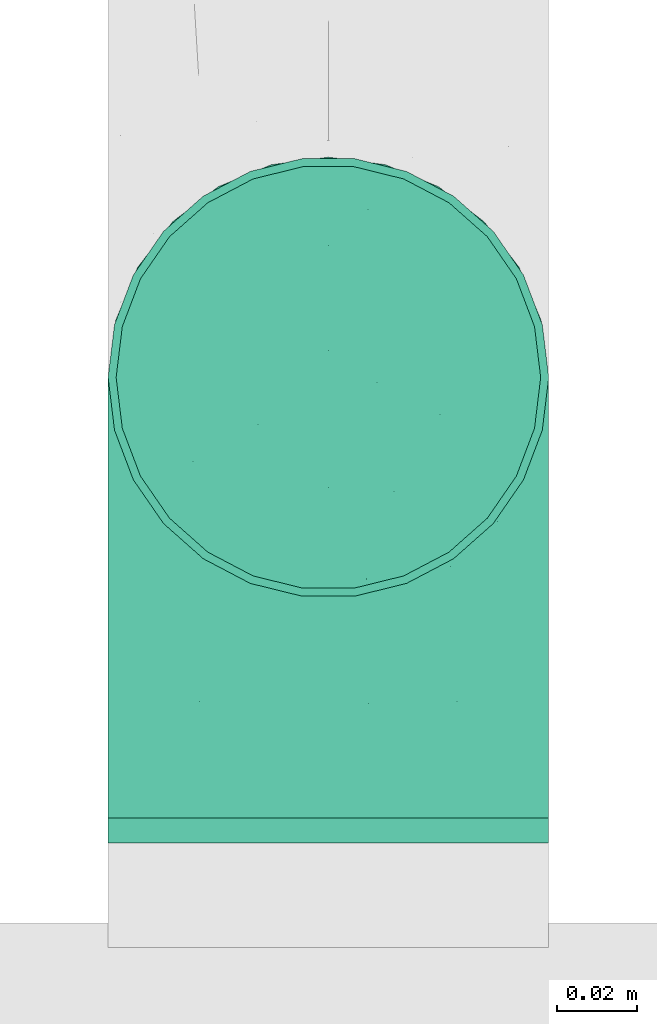
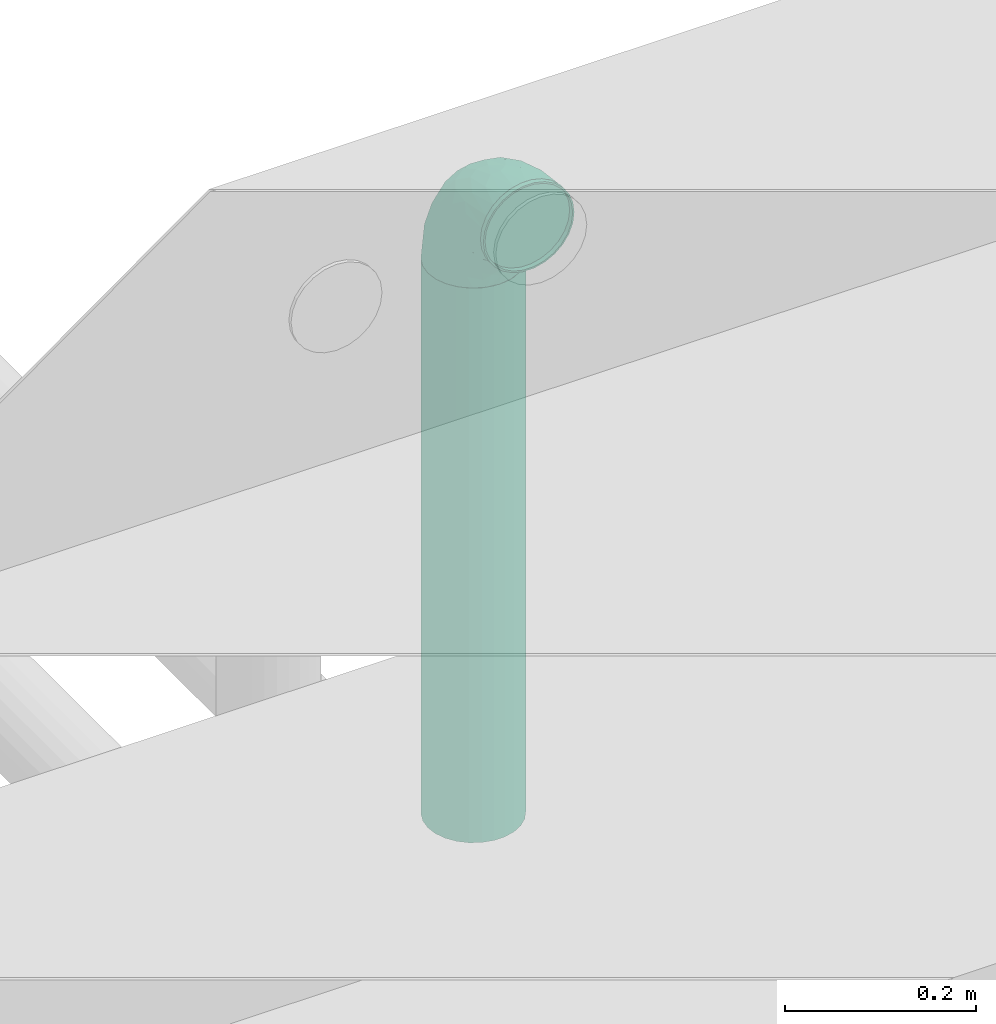
# One storey, part 30 of 91: 2 flow segments, 1 flow fitting.
"""IFC2X3 building model written with IfcOpenShell, lengths in millimetres."""

import ifcopenshell
import ifcopenshell.guid

model = None  # the IFC model being written
_history = None  # IfcOwnerHistory: only IFC2X3 demands one
_inside = {}  # id of a spatial element -> (the spatial element, [elements in it])
_under = {}  # id of a project, library or spatial element -> (it, [spatial elements below it])
_declared = {}  # id of a project -> (the project, [libraries it declares])
_typed = {}  # id of a type object -> (the type object, [elements of that type])
_made_of = {}  # id of a material, layer set ... -> (it, [elements and type objects made of it])


def new_model(schema):
    """Start an empty IFC model of exactly this schema.

    Asked for "IFC4X3", IfcOpenShell would pick the latest addendum, in which some entities
    have other attributes; the version numbers below select the first issue.
    IFC2X3 requires an IfcOwnerHistory on every rooted entity: one is made here for all.
    """
    global model, _history
    if schema == "IFC4X3":
        model = ifcopenshell.file(schema_version=(4, 3, 0, 0))
    else:
        model = ifcopenshell.file(schema=schema)
    _inside.clear()
    _under.clear()
    _declared.clear()
    _typed.clear()
    _made_of.clear()
    _history = None
    if model.schema == "IFC2X3":
        org = make("IfcOrganization", Name="unknown")
        user = make(
            "IfcPersonAndOrganization",
            ThePerson=make("IfcPerson", FamilyName="unknown"),
            TheOrganization=org,
        )
        app = make(
            "IfcApplication",
            ApplicationDeveloper=org,
            Version="unknown",
            ApplicationFullName="unknown",
            ApplicationIdentifier="unknown",
        )
        _history = make(
            "IfcOwnerHistory",
            OwningUser=user,
            OwningApplication=app,
            ChangeAction="ADDED",
            CreationDate=0,
        )
    return model


def make(cls, **values):
    """One entity of the class cls with the attributes given. An attribute that is None is left unset."""
    return model.create_entity(
        cls, **{name: value for name, value in values.items() if value is not None}
    )


def entity(cls, *values):
    """Any entity or typed value of the class cls, its attributes in the order of the schema. None: left unset."""
    e = model.create_entity(cls)
    for i, value in enumerate(values):
        if value is not None:
            e[i] = value
    return e


def rooted(cls, **values):
    """An entity with a GlobalId (a new one), such as an element, a storey or a relation."""
    return make(cls, GlobalId=ifcopenshell.guid.new(), OwnerHistory=_history, **values)


def si_unit(unit_type, name, prefix=None):
    """IfcSIUnit, for example si_unit("LENGTHUNIT", "METRE", prefix="MILLI")."""
    return make("IfcSIUnit", UnitType=unit_type, Prefix=prefix, Name=name)


def converted_unit(unit_type, name, factor, base, dimensions=None, offset=None):
    """IfcConversionBasedUnit, such as the inch: factor (a typed value) times the base unit."""
    return make(
        "IfcConversionBasedUnit"
        if offset is None
        else "IfcConversionBasedUnitWithOffset",
        ConversionOffset=offset,
        Dimensions=None
        if dimensions is None
        else entity("IfcDimensionalExponents", *dimensions),
        UnitType=unit_type,
        Name=name,
        ConversionFactor=make(
            "IfcMeasureWithUnit", ValueComponent=factor, UnitComponent=base
        ),
    )


def derived_unit(unit_type, elements):
    """IfcDerivedUnit: a product of units, each with its exponent."""
    return make(
        "IfcDerivedUnit",
        Elements=[
            make("IfcDerivedUnitElement", Unit=unit, Exponent=power)
            for unit, power in elements
        ],
        UnitType=unit_type,
    )


def assignment(units):
    """IfcUnitAssignment: the units of a project."""
    return None if units is None else make("IfcUnitAssignment", Units=units)


def point(xyz):
    """IfcCartesianPoint."""
    return None if xyz is None else make("IfcCartesianPoint", Coordinates=xyz)


def direction(xyz):
    """IfcDirection."""
    return None if xyz is None else make("IfcDirection", DirectionRatios=xyz)


def frame(location, z_axis=None, x_axis=None):
    """IfcAxis2Placement3D, a coordinate frame: its origin and axes. An axis left out is left unset."""
    return make(
        "IfcAxis2Placement3D",
        Location=point(location),
        Axis=direction(z_axis),
        RefDirection=direction(x_axis),
    )


def frame_2d(location, x_axis=None):
    """IfcAxis2Placement2D, a coordinate frame in the plane: its origin and x axis."""
    return make(
        "IfcAxis2Placement2D", Location=point(location), RefDirection=direction(x_axis)
    )


def origin_with_axes():
    """The frame at (0, 0, 0) with the z axis (0, 0, 1) and the x axis (1, 0, 0) written out."""
    return frame((0.0, 0.0, 0.0), z_axis=(0.0, 0.0, 1.0), x_axis=(1.0, 0.0, 0.0))


def origin_2d_with_axis():
    """The frame at (0, 0) in the plane with the x axis (1, 0) written out."""
    return frame_2d((0.0, 0.0), x_axis=(1.0, 0.0))


def place(relative_to, where):
    """IfcLocalPlacement: puts the frame where relative to a parent placement (None: the world)."""
    return make(
        "IfcLocalPlacement", PlacementRelTo=relative_to, RelativePlacement=where
    )


def context(
    kind, dimensions, precision=None, world=None, true_north=None, identifier=None
):
    """IfcGeometricRepresentationContext, for example the 3D "Model" context."""
    return make(
        "IfcGeometricRepresentationContext",
        ContextIdentifier=identifier,
        ContextType=kind,
        CoordinateSpaceDimension=dimensions,
        Precision=precision,
        WorldCoordinateSystem=world,
        TrueNorth=true_north,
    )


def subcontext(parent, identifier, kind, view, scale=None):
    """IfcGeometricRepresentationSubContext, for example "Body" below "Model"."""
    return make(
        "IfcGeometricRepresentationSubContext",
        ContextIdentifier=identifier,
        ContextType=kind,
        ParentContext=parent,
        TargetScale=scale,
        TargetView=view,
    )


def project(units=None, contexts=None):
    """IfcProject with its units and contexts."""
    return rooted(
        "IfcProject",
        Name="project",
        RepresentationContexts=contexts,
        UnitsInContext=assignment(units),
    )


def spatial(cls, under=None, at=None, **own):
    """A site, building, storey or space (cls), placed at a placement, below another one or the project."""
    s = rooted(cls, ObjectPlacement=at, **own)
    if under is not None:
        _under.setdefault(under.id(), (under, []))[1].append(s)
    return s


def profile(cls, at=None, kind="AREA", **sizes):
    """A parametric profile (cls). Its sizes go by their IFC names, for example OverallWidth=200.0."""
    return make(cls, ProfileType=kind, Position=at, **sizes)


def hollow_circle(**sizes):
    """IfcCircleHollowProfileDef."""
    return profile("IfcCircleHollowProfileDef", **sizes)


def extrude(swept, where, along, depth):
    """IfcExtrudedAreaSolid: the profile swept, set in the frame where, extruded along a direction by depth."""
    return make(
        "IfcExtrudedAreaSolid",
        SweptArea=swept,
        Position=where,
        ExtrudedDirection=direction(along),
        Depth=depth,
    )


def faces_of(points, faces, orient=None, outer=None):
    """IfcFace entities. A face is a list of loops; a loop is a list of indices into points, from 0.

    orient and outer hold one flag for each loop. By default every Orientation is true, the
    first loop of a face is its IfcFaceOuterBound and the others are IfcFaceBound.
    """
    made = []
    for i, loops in enumerate(faces):
        bounds = []
        for j, loop in enumerate(loops):
            is_outer = j == 0 if outer is None else outer[i][j]
            bounds.append(
                make(
                    "IfcFaceOuterBound" if is_outer else "IfcFaceBound",
                    Bound=make("IfcPolyLoop", Polygon=[points[k] for k in loop]),
                    Orientation=True if orient is None else orient[i][j],
                )
            )
        made.append(make("IfcFace", Bounds=bounds))
    return made


def open_shell(faces, orient=None, outer=None):
    """The faces of one IfcOpenShell. surface_model builds it on its shared points."""
    return ("IfcOpenShell", faces, orient, outer)


def surface_model(cls, points, shells):
    """IfcFaceBasedSurfaceModel or IfcShellBasedSurfaceModel (cls): surfaces that need not close."""
    shared = [point(p) for p in points]
    made = [make(c, CfsFaces=faces_of(shared, fs, o, b)) for c, fs, o, b in shells]
    if cls == "IfcFaceBasedSurfaceModel":
        return make(cls, FbsmFaces=made)
    return make(cls, SbsmBoundary=made)


def shape(context_of_items, identifier, shape_type, items):
    """IfcShapeRepresentation: the items that make up one representation, for example the "Body"."""
    return make(
        "IfcShapeRepresentation",
        ContextOfItems=context_of_items,
        RepresentationIdentifier=identifier,
        RepresentationType=shape_type,
        Items=items,
    )


def source(mapping_origin, context_of_items, identifier, shape_type, items):
    """IfcRepresentationMap: a shape defined once, which mapped items show again and again."""
    return make(
        "IfcRepresentationMap",
        MappingOrigin=mapping_origin,
        MappedRepresentation=shape(context_of_items, identifier, shape_type, items),
    )


def transform(
    local_origin,
    x_axis=None,
    y_axis=None,
    z_axis=None,
    scale=None,
    scale2=None,
    scale3=None,
    uniform=True,
):
    """IfcCartesianTransformationOperator3D, or its non-uniform kind. x_axis, y_axis, z_axis: its Axis1, 2, 3."""
    if uniform:
        return make(
            "IfcCartesianTransformationOperator3D",
            Axis1=direction(x_axis),
            Axis2=direction(y_axis),
            LocalOrigin=point(local_origin),
            Scale=scale,
            Axis3=direction(z_axis),
        )
    return make(
        "IfcCartesianTransformationOperator3DnonUniform",
        Axis1=direction(x_axis),
        Axis2=direction(y_axis),
        LocalOrigin=point(local_origin),
        Scale=scale,
        Axis3=direction(z_axis),
        Scale2=scale2,
        Scale3=scale3,
    )


def mapped(mapping_source, mapping_target):
    """IfcMappedItem: shows the shape of a source again, moved by a transform."""
    return make(
        "IfcMappedItem", MappingSource=mapping_source, MappingTarget=mapping_target
    )


def material(Name=None, Category=None):
    """IfcMaterial."""
    return make("IfcMaterial", Name=Name, Category=Category)


def layer(
    of_material, thickness, ventilated=None, Name=None, Category=None, Priority=None
):
    """IfcMaterialLayer: one layer of a wall or slab, of a material (None: an air gap)."""
    return make(
        "IfcMaterialLayer",
        Material=of_material,
        LayerThickness=thickness,
        IsVentilated=ventilated,
        Name=Name,
        Category=Category,
        Priority=Priority,
    )


def layer_set(layers, Name=None):
    """IfcMaterialLayerSet."""
    return make("IfcMaterialLayerSet", MaterialLayers=layers, LayerSetName=Name)


def layer_usage(for_layer_set, set_direction, sense, offset, extent=None):
    """IfcMaterialLayerSetUsage: how a layer set lies in its element."""
    return make(
        "IfcMaterialLayerSetUsage",
        ForLayerSet=for_layer_set,
        LayerSetDirection=set_direction,
        DirectionSense=sense,
        OffsetFromReferenceLine=offset,
        ReferenceExtent=extent,
    )


def made_of(thing, what):
    """Note that an element or type object is made of a material, layer set ...; save() writes the relation."""
    if what is not None:
        _made_of.setdefault(what.id(), (what, []))[1].append(thing)
    return thing


def type_object(cls, material=None, **own):
    """A type object (cls), such as IfcWallType, which elements share."""
    return made_of(rooted(cls, **own), material)


def element(
    cls,
    number,
    at=None,
    inside=None,
    cuts=None,
    type_object=None,
    material=None,
    context=None,
    identifier="Body",
    shape_type=None,
    held_by="IfcProductDefinitionShape",
    body=None,
    shapes=None,
    **own,
):
    """One element of the class cls, such as IfcWall. Its Tag is "e" and its number.

    at: its placement. inside: the storey or other place that contains it. cuts: it is an
    opening in that element (IfcRelVoidsElement). A single representation is given by context,
    identifier, shape_type and body (its items); several are given by shapes. held_by: the class
    of the entity that holds the representations. save() writes the other relations.
    """
    e = rooted(cls, Tag="e%d" % number, ObjectPlacement=at, **own)
    if body is not None:
        shapes = [shape(context, identifier, shape_type, body)]
    if shapes is not None:
        e.Representation = make(held_by, Representations=shapes)
    if inside is not None:
        _inside.setdefault(inside.id(), (inside, []))[1].append(e)
    if cuts is not None:
        rooted(
            "IfcRelVoidsElement", RelatingBuildingElement=cuts, RelatedOpeningElement=e
        )
    if type_object is not None:
        _typed.setdefault(type_object.id(), (type_object, []))[1].append(e)
    return made_of(e, material)


def aggregate(whole, parts):
    """IfcRelAggregates: a whole, such as a stair, and the parts it consists of."""
    return rooted("IfcRelAggregates", RelatingObject=whole, RelatedObjects=parts)


def save(model, path):
    """Write the relations noted so far, then the file.

    IfcRelAggregates (storeys below a building ...), IfcRelContainedInSpatialStructure (elements
    in a storey), IfcRelDefinesByType, IfcRelAssociatesMaterial and IfcRelDeclares: one each for
    every whole, place, type object, material and project.
    """
    for whole, parts in _under.values():
        aggregate(whole, parts)
    for where, things in _inside.values():
        rooted(
            "IfcRelContainedInSpatialStructure",
            RelatedElements=things,
            RelatingStructure=where,
        )
    for kind, things in _typed.values():
        rooted("IfcRelDefinesByType", RelatedObjects=things, RelatingType=kind)
    for what, things in _made_of.values():
        rooted("IfcRelAssociatesMaterial", RelatedObjects=things, RelatingMaterial=what)
    for by, libraries in _declared.values():
        rooted("IfcRelDeclares", RelatingContext=by, RelatedDefinitions=libraries)
    model.write(path)


model = new_model("IFC2X3")

# Units and contexts
model_context = context("Model", 3, precision=1e-05, world=origin_with_axes(), true_north=direction((0.0, 1.0)))
body_context = subcontext(model_context, "Body", "Model", "MODEL_VIEW")
ifc_project = project(units=[si_unit("AREAUNIT", "SQUARE_METRE"), si_unit("VOLUMEUNIT", "CUBIC_METRE", prefix="DECI"), si_unit("TIMEUNIT", "SECOND"), si_unit("THERMODYNAMICTEMPERATUREUNIT", "DEGREE_CELSIUS"), si_unit("PRESSUREUNIT", "PASCAL"), si_unit("MASSUNIT", "GRAM", prefix="KILO"), si_unit("LENGTHUNIT", "METRE", prefix="MILLI"), si_unit("POWERUNIT", "WATT"), si_unit("ELECTRICCURRENTUNIT", "AMPERE"), si_unit("ELECTRICVOLTAGEUNIT", "VOLT"), derived_unit("VOLUMETRICFLOWRATEUNIT", [(si_unit("VOLUMEUNIT", "CUBIC_METRE", prefix="DECI"), 1), (si_unit("TIMEUNIT", "SECOND"), -1)]), derived_unit("LINEARVELOCITYUNIT", [(si_unit("LENGTHUNIT", "METRE"), 1), (si_unit("TIMEUNIT", "SECOND"), -1)]), derived_unit("MASSDENSITYUNIT", [(si_unit("MASSUNIT", "GRAM", prefix="KILO"), 1), (si_unit("VOLUMEUNIT", "CUBIC_METRE"), -1)]), converted_unit("PLANEANGLEUNIT", "DEGREE", entity("IfcRatioMeasure", 0.01745), si_unit("PLANEANGLEUNIT", "RADIAN"), dimensions=[0, 0, 0, 0, 0, 0, 0])], contexts=[model_context])

# Site, building, storey
site_placement = place(None, origin_with_axes())
site = spatial("IfcSite", under=ifc_project, at=site_placement, CompositionType="ELEMENT")
building_placement = place(site_placement, origin_with_axes())
building = spatial("IfcBuilding", under=site, at=building_placement, Name="mc-building", CompositionType="ELEMENT")
storey_placement = place(building_placement, frame((0.0, 0.0, 8700.0), z_axis=(0.0, 0.0, 1.0), x_axis=(1.0, 0.0, 0.0)))
storey = spatial("IfcBuildingStorey", under=building, at=storey_placement, CompositionType="ELEMENT", Elevation=8700.0)

# Flow segment
ifc_material = material(Name="FZ1")
ifc_layer = layer(ifc_material, 0.0)
ifc_layer_set = layer_set([ifc_layer], Name="FZ1")
ifc_layer_usage = layer_usage(ifc_layer_set, "AXIS1", "POSITIVE", 0.0)
duct_segment_type = type_object("IfcDuctSegmentType", PredefinedType="RIGIDSEGMENT")
shared_shape_1 = source(origin_with_axes(), body_context, "Body", "SweptSolid", [
    extrude(hollow_circle(Radius=55.0, WallThickness=2.0, at=origin_2d_with_axis()), frame((0.0, 0.0, 0.0), z_axis=(1.0, 0.0, 0.0), x_axis=(0.0, 1.0, 0.0)), (0.0, 0.0, 1.0), 709.0),
])
flow_segment_1_placement = place(storey_placement, frame((12366.76802, 8426.54565, 1234.0), z_axis=(0.0, 1.0, 0.0), x_axis=(0.0, 0.0, -1.0)))
element("IfcFlowSegment", 1, at=flow_segment_1_placement, inside=storey, type_object=duct_segment_type, material=ifc_layer_usage, context=body_context, shape_type="MappedRepresentation", body=[
    mapped(shared_shape_1, transform((0.0, 0.0, 0.0), scale=1.0)),
])

# Flow fitting
duct_fitting_type = type_object("IfcDuctFittingType", Name="BU", PredefinedType="BEND")
shared_shape_2 = source(origin_with_axes(), body_context, "Body", "SurfaceModel", [
    surface_model("IfcShellBasedSurfaceModel", [(-110.0, 0.0, -55.0), (-110.0, -14.23505, -53.12592), (-110.0, 14.23505, -53.12592), (-110.0, 53.12592, 14.23505), (-110.0, 27.5, -47.63139), (-110.0, 38.89087, -38.89087), (-110.0, -55.0, 0.0), (-110.0, -53.12592, 14.23505), (-110.0, -38.89087, -38.89087), (-110.0, -27.5, -47.63139), (-110.0, -53.12592, -14.23505), (-110.0, -47.63139, -27.5), (-110.0, -14.23505, 53.12592), (-110.0, 14.23505, 53.12592), (-110.0, 27.5, 47.63139), (-110.0, -47.63139, 27.5), (-110.0, -38.89087, 38.89087), (-110.0, -27.5, 47.63139), (-110.0, 0.0, 55.0), (-110.0, 55.0, 0.0), (-110.0, 53.12592, -14.23505), (-110.0, 47.63139, -27.5), (-110.0, 47.63139, 27.5), (-110.0, 38.89087, 38.89087), (-14.23505, 110.0, -53.12592), (-55.0, 110.0, 0.0), (0.0, 110.0, -55.0), (-27.5, 110.0, -47.63139), (-38.89087, 110.0, -38.89087), (-47.63139, 110.0, -27.5), (38.89087, 110.0, -38.89087), (53.12592, 110.0, 14.23505), (27.5, 110.0, -47.63139), (14.23505, 110.0, -53.12592), (47.63139, 110.0, -27.5), (53.12592, 110.0, -14.23505), (55.0, 110.0, 0.0), (-53.12592, 110.0, -14.23505), (-53.12592, 110.0, 14.23505), (-47.63139, 110.0, 27.5), (-38.89087, 110.0, 38.89087), (-27.5, 110.0, 47.63139), (0.0, 110.0, 55.0), (-14.23505, 110.0, 53.12592), (38.89087, 110.0, 38.89087), (47.63139, 110.0, 27.5), (27.5, 110.0, 47.63139), (14.23505, 110.0, 53.12592), (-64.21732, 48.68956, 43.63444), (-76.6405, 38.18013, 45.55988), (-60.44912, 32.56953, 51.94617), (-76.00813, 5.38378, 55.0), (-90.15553, 11.94394, 54.09138), (-78.5998, 26.77405, 50.81338), (-70.18771, 18.55163, 54.03432), (-75.55424, 54.2118, 32.41257), (-93.27622, 45.77614, 33.48188), (-96.12334, 22.13664, 50.81337), (-21.00813, 45.34362, 55.0), (-18.36258, 70.48427, 54.04484), (-32.04182, 59.64019, 52.24446), (-63.88653, 74.77858, 17.99134), (-74.66383, 63.08407, 19.92123), (-63.60674, 66.07878, 29.97482), (-99.597, 52.72185, 18.52927), (-93.11138, 56.59448, 10.50359), (-98.21577, 57.34403, 0.0), (-53.42855, 92.60092, 21.04759), (-88.54852, 54.8376, 21.04759), (-11.86161, 90.23965, 54.10313), (-5.38378, 76.00813, 55.0), (-57.34403, 98.21577, 0.0), (-56.64619, 93.12774, 10.22088), (-45.34362, 21.00813, 55.0), (-44.60838, 44.60838, 52.13415), (-92.68484, 35.46673, 43.63443), (-22.25266, 95.40765, 50.81337), (-35.97783, 90.61597, 43.63443), (-43.70931, 69.58671, 44.47149), (-27.23711, 77.39884, 50.81337), (-57.2828, 79.3123, 24.9774), (-58.67786, 84.31125, 16.04456), (-82.93277, 60.36161, 12.91784), (-49.88337, 54.51816, 47.224), (-74.57753, 66.83759, 9.55742), (-45.35812, 94.97281, 33.48188), (-59.18663, 88.95241, 0.0), (-51.517, 78.6292, 33.48188), (-65.14788, 80.03077, 0.0), (-56.45322, 62.06476, 39.63545), (-88.95241, 59.18663, 0.0), (-71.10913, 71.10913, 0.0), (-80.03077, 65.14788, 0.0), (-94.9309, 45.36788, -33.48188), (-93.11358, 56.60141, -10.46614), (-99.64997, 52.79499, -18.30015), (-90.20425, 36.08686, -43.63443), (-79.99933, 46.56772, -37.92748), (-76.00813, 5.38378, -55.0), (-72.75364, 19.68651, -53.60527), (-45.34362, 21.00813, -55.0), (-21.91957, 65.12078, -53.85897), (-5.38378, 76.00813, -55.0), (-21.00813, 45.34362, -55.0), (-35.41876, 92.89265, -43.63443), (-91.10309, 11.02766, -54.21832), (-45.77614, 93.27622, -33.48188), (-90.50474, 23.21022, -50.81337), (-70.92854, 33.31794, -49.51754), (-78.52933, 63.35627, -11.73997), (-24.91508, 84.05606, -50.81337), (-88.78941, 54.74452, -21.04759), (-69.59921, 57.34866, -33.48187), (-73.36422, 62.46673, -22.94182), (-63.49062, 67.59111, -28.46929), (-56.59448, 93.11138, -10.50359), (-54.8376, 88.54852, -21.04759), (-54.10679, 75.85581, -32.31867), (-57.75956, 31.09612, -52.80882), (-52.72185, 99.597, -18.52927), (-12.62913, 89.46304, -53.99097), (-34.46825, 66.46123, -50.04329), (-43.9837, 43.9837, -52.42279), (-65.78527, 72.58348, -17.68796), (-70.34468, 43.65295, -44.21951), (-57.47001, 51.99467, -44.91465), (-60.72547, 82.29174, -12.88567), (-42.34915, 74.24548, -43.63444), (-57.25194, 63.5016, -38.08211), (-80.95344, 53.56991, -29.32027), (-52.32891, 4.55257, -54.0482), (32.52942, 47.13398, -30.48571), (14.88266, 20.92917, -33.7947), (14.95561, 36.05775, -42.26543), (30.24048, 70.09027, -41.7461), (19.3559, 65.35825, -48.00507), (-70.35075, -46.44478, -19.5952), (-47.13398, -32.52942, -30.48571), (-28.49299, -30.5778, -16.4009), (-4.55257, 52.32891, -54.0482), (-22.4954, 22.4954, -53.25347), (-75.47368, -11.22546, -52.60718), (-81.32209, -51.5606, -9.98467), (-80.81763, -41.84862, -32.14655), (-70.09027, -30.24048, -41.7461), (-36.05774, -14.95561, -42.26543), (-9.15831, -10.852, -27.8997), (-65.35825, -19.3559, -48.00507), (11.22546, 75.47368, -52.60718), (3.94376, 43.9333, -50.53315), (-13.39742, 13.39743, -48.13058), (-43.9333, -3.94376, -50.53315), (49.37776, 67.29486, 0.0), (41.8609, 47.82256, -9.92641), (50.20582, 74.51695, -9.9731), (18.93131, 11.7156, -17.56239), (-27.5, -32.89419, 0.0), (-1.23348, -12.25375, -12.18106), (41.84862, 80.81763, -32.14655), (35.70604, 41.31408, -20.38235), (46.44478, 70.35075, -19.5952), (32.89419, 27.5, 0.0), (6.67262, -6.67262, 0.0), (-67.29486, -49.37776, 0.0), (-50.36265, -42.95545, -9.51562), (-5.47251, 5.47251, -39.92906), (-70.35075, -46.44478, 19.5952), (-74.51695, -50.20582, 9.9731), (-41.31407, -35.70604, 20.38235), (-47.13398, -32.52942, 30.48571), (-80.81763, -41.84862, 32.14655), (-4.55257, 52.32891, 54.0482), (11.22546, 75.47368, 52.60718), (-43.9333, -3.94376, 50.53315), (-65.35825, -19.3559, 48.00507), (-36.05774, -14.95561, 42.26543), (-70.09027, -30.24048, 41.7461), (-11.7156, -18.93131, 17.56239), (30.5778, 28.49299, 16.4009), (12.25375, 1.23348, 12.18106), (51.5606, 81.32209, 9.98467), (42.95545, 50.36265, 9.51562), (-75.47368, -11.22546, 52.60718), (-52.32891, 4.55257, 54.0482), (3.94376, 43.9333, 50.53315), (-22.4954, 22.4954, 53.25347), (-13.39742, 13.39743, 48.13058), (10.852, 9.15831, 27.8997), (-20.92916, -14.88266, 33.79469), (-47.82256, -41.8609, 9.92641), (32.52942, 47.13398, 30.48571), (46.44478, 70.35075, 19.5952), (41.84862, 80.81763, 32.14655), (30.24048, 70.09027, 41.7461), (19.3559, 65.35825, 48.00507), (14.95561, 36.05775, 42.26543), (-5.47251, 5.47251, 39.92906)], [open_shell([[[0, 1, 2]], [[2, 3, 4]], [[4, 3, 5]], [[2, 6, 7]], [[8, 6, 9]], [[1, 9, 6]], [[10, 6, 11]], [[8, 11, 6]], [[6, 2, 1]], [[12, 13, 14]], [[15, 2, 7]], [[16, 17, 2]], [[2, 17, 12]], [[12, 18, 13]], [[19, 20, 3]], [[5, 3, 21]], [[20, 21, 3]], [[22, 3, 2]], [[23, 22, 2]], [[12, 14, 2]], [[2, 14, 23]], [[15, 16, 2]], [[24, 25, 26]], [[27, 25, 24]], [[25, 28, 29]], [[28, 25, 27]], [[30, 26, 31]], [[26, 30, 32]], [[32, 33, 26]], [[34, 31, 35]], [[31, 34, 30]], [[35, 31, 36]], [[29, 37, 25]], [[38, 39, 26]], [[39, 40, 26]], [[41, 42, 40]], [[42, 26, 40]], [[42, 41, 43]], [[26, 44, 45]], [[31, 26, 45]], [[26, 46, 44]], [[47, 46, 26]], [[42, 47, 26]], [[25, 38, 26]], [[48, 49, 50]], [[18, 51, 52]], [[53, 54, 50]], [[55, 56, 49]], [[56, 22, 23]], [[13, 57, 14]], [[58, 59, 60]], [[61, 62, 63]], [[3, 64, 65]], [[53, 52, 54]], [[3, 65, 66]], [[67, 39, 38]], [[56, 68, 64]], [[65, 64, 68]], [[69, 59, 70]], [[38, 71, 72]], [[73, 58, 74]], [[75, 49, 56]], [[76, 69, 43]], [[53, 57, 52]], [[77, 78, 79]], [[41, 76, 43]], [[43, 69, 42]], [[55, 68, 56]], [[23, 14, 75]], [[76, 77, 79]], [[80, 67, 81]], [[62, 82, 68]], [[60, 78, 83]], [[62, 84, 82]], [[85, 77, 40]], [[81, 67, 72]], [[86, 72, 71]], [[87, 85, 67]], [[61, 81, 88]], [[77, 41, 40]], [[78, 77, 87]], [[23, 75, 56]], [[83, 89, 48]], [[85, 40, 39]], [[62, 68, 55]], [[89, 87, 63]], [[83, 48, 50]], [[57, 75, 14]], [[49, 75, 53]], [[67, 85, 39]], [[87, 77, 85]], [[63, 62, 55]], [[89, 55, 48]], [[80, 63, 87]], [[66, 65, 90]], [[66, 19, 3]], [[84, 91, 92]], [[92, 90, 82]], [[65, 82, 90]], [[61, 84, 62]], [[92, 82, 84]], [[68, 82, 65]], [[3, 22, 64]], [[56, 64, 22]], [[38, 25, 71]], [[81, 72, 86]], [[38, 72, 67]], [[91, 61, 88]], [[80, 81, 61]], [[63, 80, 61]], [[67, 80, 87]], [[77, 76, 41]], [[79, 59, 69]], [[79, 69, 76]], [[42, 69, 70]], [[60, 59, 79]], [[58, 70, 59]], [[78, 60, 79]], [[58, 60, 74]], [[52, 57, 13]], [[75, 57, 53]], [[18, 52, 13]], [[52, 51, 54]], [[51, 73, 54]], [[50, 73, 74]], [[73, 50, 54]], [[50, 74, 83]], [[60, 83, 74]], [[89, 83, 78]], [[87, 89, 78]], [[55, 89, 63]], [[50, 49, 53]], [[55, 49, 48]], [[81, 86, 88]], [[91, 84, 61]], [[5, 21, 93]], [[90, 94, 66]], [[20, 94, 95]], [[96, 93, 97]], [[98, 99, 100]], [[96, 4, 5]], [[101, 102, 103]], [[28, 27, 104]], [[2, 105, 0]], [[104, 106, 28]], [[99, 105, 107]], [[108, 107, 96]], [[90, 109, 94]], [[107, 2, 4]], [[20, 66, 94]], [[27, 24, 110]], [[109, 111, 94]], [[112, 113, 114]], [[37, 115, 71]], [[116, 106, 117]], [[99, 118, 100]], [[116, 115, 119]], [[37, 119, 115]], [[24, 120, 110]], [[121, 110, 101]], [[119, 106, 116]], [[101, 110, 120]], [[122, 103, 100]], [[117, 123, 116]], [[124, 125, 108]], [[115, 116, 126]], [[106, 29, 28]], [[26, 102, 120]], [[127, 104, 110]], [[97, 124, 96]], [[125, 122, 118]], [[128, 127, 125]], [[96, 5, 93]], [[115, 126, 86]], [[117, 106, 127]], [[111, 113, 129]], [[95, 93, 21]], [[97, 129, 112]], [[110, 104, 27]], [[106, 104, 127]], [[96, 107, 4]], [[99, 107, 108]], [[99, 108, 118]], [[105, 99, 98]], [[112, 114, 128]], [[121, 125, 127]], [[20, 19, 66]], [[109, 90, 92]], [[94, 111, 95]], [[91, 123, 109]], [[129, 113, 112]], [[93, 95, 111]], [[21, 20, 95]], [[71, 115, 86]], [[71, 25, 37]], [[123, 91, 88]], [[126, 116, 123]], [[123, 88, 126]], [[86, 126, 88]], [[37, 29, 119]], [[106, 119, 29]], [[129, 93, 111]], [[124, 112, 125]], [[0, 105, 98]], [[107, 105, 2]], [[125, 118, 108]], [[100, 118, 122]], [[93, 129, 97]], [[113, 111, 109]], [[109, 123, 113]], [[114, 123, 117]], [[123, 114, 113]], [[128, 114, 117]], [[127, 128, 117]], [[112, 128, 125]], [[103, 122, 101]], [[110, 121, 127]], [[101, 122, 121]], [[125, 121, 122]], [[26, 120, 24]], [[101, 120, 102]], [[96, 124, 108]], [[92, 91, 109]], [[112, 124, 97]], [[100, 130, 98]], [[131, 132, 133]], [[32, 134, 135]], [[136, 137, 138]], [[139, 140, 103]], [[98, 141, 0]], [[142, 10, 136]], [[143, 144, 137]], [[6, 10, 142]], [[137, 145, 146]], [[144, 147, 145]], [[143, 136, 11]], [[11, 136, 10]], [[8, 143, 11]], [[148, 149, 139]], [[8, 9, 144]], [[9, 1, 147]], [[130, 141, 98]], [[103, 140, 100]], [[148, 135, 149]], [[150, 151, 140]], [[152, 153, 154]], [[130, 140, 151]], [[148, 26, 33]], [[147, 1, 141]], [[155, 146, 132]], [[156, 138, 157]], [[134, 30, 158]], [[150, 140, 149]], [[158, 30, 34]], [[30, 134, 32]], [[153, 159, 160]], [[131, 160, 159]], [[144, 145, 137]], [[36, 152, 154]], [[146, 138, 137]], [[155, 161, 162]], [[158, 160, 131]], [[133, 149, 135]], [[156, 163, 164]], [[163, 142, 164]], [[139, 103, 102]], [[153, 152, 161]], [[34, 35, 160]], [[162, 157, 155]], [[132, 165, 133]], [[157, 146, 155]], [[140, 130, 100]], [[141, 130, 151]], [[141, 151, 147]], [[141, 1, 0]], [[102, 26, 148]], [[140, 139, 149]], [[102, 148, 139]], [[135, 33, 32]], [[151, 150, 145]], [[9, 147, 144]], [[151, 145, 147]], [[145, 165, 146]], [[135, 148, 33]], [[133, 135, 134]], [[131, 133, 134]], [[133, 165, 150]], [[133, 150, 149]], [[145, 150, 165]], [[132, 131, 159]], [[146, 165, 132]], [[160, 158, 34]], [[134, 158, 131]], [[144, 143, 8]], [[136, 143, 137]], [[155, 153, 161]], [[154, 153, 160]], [[153, 155, 159]], [[132, 159, 155]], [[160, 35, 154]], [[36, 154, 35]], [[164, 136, 138]], [[6, 142, 163]], [[136, 164, 142]], [[156, 164, 138]], [[156, 157, 162]], [[146, 157, 138]], [[15, 7, 166]], [[6, 163, 167]], [[168, 169, 166]], [[166, 169, 170]], [[171, 172, 70]], [[173, 174, 175]], [[17, 176, 174]], [[177, 156, 162]], [[176, 16, 170]], [[170, 16, 15]], [[161, 178, 179]], [[152, 180, 181]], [[182, 173, 183]], [[18, 12, 182]], [[184, 185, 186]], [[183, 185, 73]], [[183, 73, 51]], [[177, 187, 188]], [[189, 168, 166]], [[187, 178, 190]], [[16, 176, 17]], [[161, 152, 181]], [[45, 191, 31]], [[45, 44, 192]], [[192, 191, 45]], [[180, 36, 31]], [[193, 194, 195]], [[46, 47, 194]], [[193, 195, 190]], [[193, 44, 46]], [[172, 42, 70]], [[185, 58, 73]], [[189, 163, 156]], [[163, 189, 167]], [[70, 58, 171]], [[184, 171, 185]], [[169, 188, 175]], [[180, 31, 191]], [[192, 193, 190]], [[191, 190, 178]], [[182, 174, 173]], [[194, 47, 172]], [[190, 195, 187]], [[186, 185, 173]], [[162, 179, 177]], [[188, 196, 175]], [[179, 187, 177]], [[185, 171, 58]], [[172, 171, 184]], [[172, 184, 194]], [[172, 47, 42]], [[51, 18, 182]], [[185, 183, 173]], [[51, 182, 183]], [[174, 12, 17]], [[184, 186, 195]], [[46, 194, 193]], [[184, 195, 194]], [[195, 196, 187]], [[174, 182, 12]], [[175, 174, 176]], [[169, 175, 176]], [[175, 196, 186]], [[175, 186, 173]], [[195, 186, 196]], [[188, 169, 168]], [[187, 196, 188]], [[166, 170, 15]], [[176, 170, 169]], [[193, 192, 44]], [[191, 192, 190]], [[177, 189, 156]], [[167, 189, 166]], [[189, 177, 168]], [[188, 168, 177]], [[166, 7, 167]], [[6, 167, 7]], [[181, 191, 178]], [[36, 180, 152]], [[191, 181, 180]], [[161, 181, 178]], [[161, 179, 162]], [[187, 179, 178]]])]),
])
flow_fitting_placement = place(storey_placement, frame((12366.76802, 8426.54565, 1344.0), z_axis=(1.0, 0.0, 0.0), x_axis=(0.0, 0.0, 1.0)))
element("IfcFlowFitting", 2, at=flow_fitting_placement, inside=storey, type_object=duct_fitting_type, Name="BU", context=body_context, shape_type="MappedRepresentation", body=[
    mapped(shared_shape_2, transform((0.0, 0.0, 0.0), scale=1.0)),
])

# Flow segment
shared_shape_3 = source(origin_with_axes(), body_context, "Body", "SweptSolid", [
    extrude(hollow_circle(Radius=55.0, WallThickness=2.0, at=origin_2d_with_axis()), frame((0.0, 0.0, 0.0), z_axis=(1.0, 0.0, 0.0), x_axis=(0.0, 1.0, 0.0)), (0.0, 0.0, 1.0), 6.2),
])
flow_segment_2_placement = place(storey_placement, frame((12366.76802, 8310.34565, 1344.0), z_axis=(0.0, 0.0, 1.0), x_axis=(0.0, 1.0, 0.0)))
element("IfcFlowSegment", 3, at=flow_segment_2_placement, inside=storey, type_object=duct_segment_type, material=ifc_layer_usage, context=body_context, shape_type="MappedRepresentation", body=[
    mapped(shared_shape_3, transform((0.0, 0.0, 0.0), scale=1.0, scale2=1.0, scale3=1.0, uniform=False)),
])

save(model, "model.ifc")
